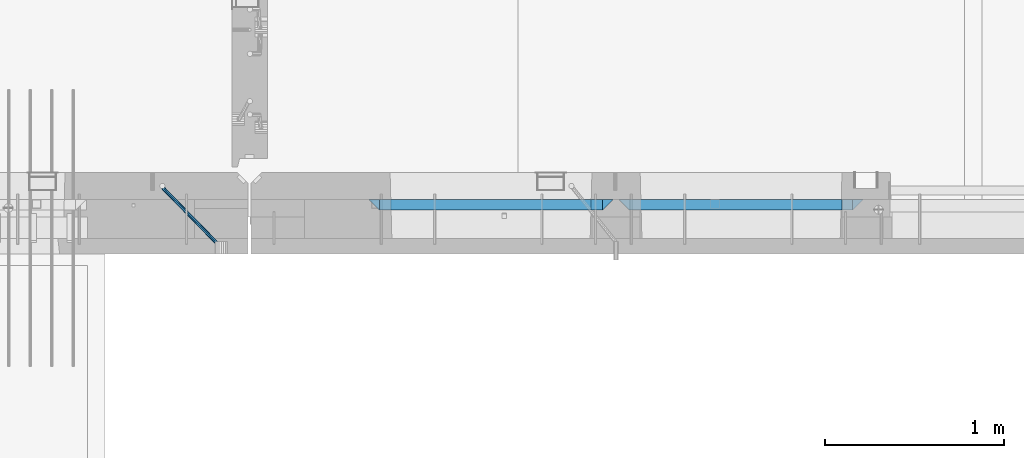
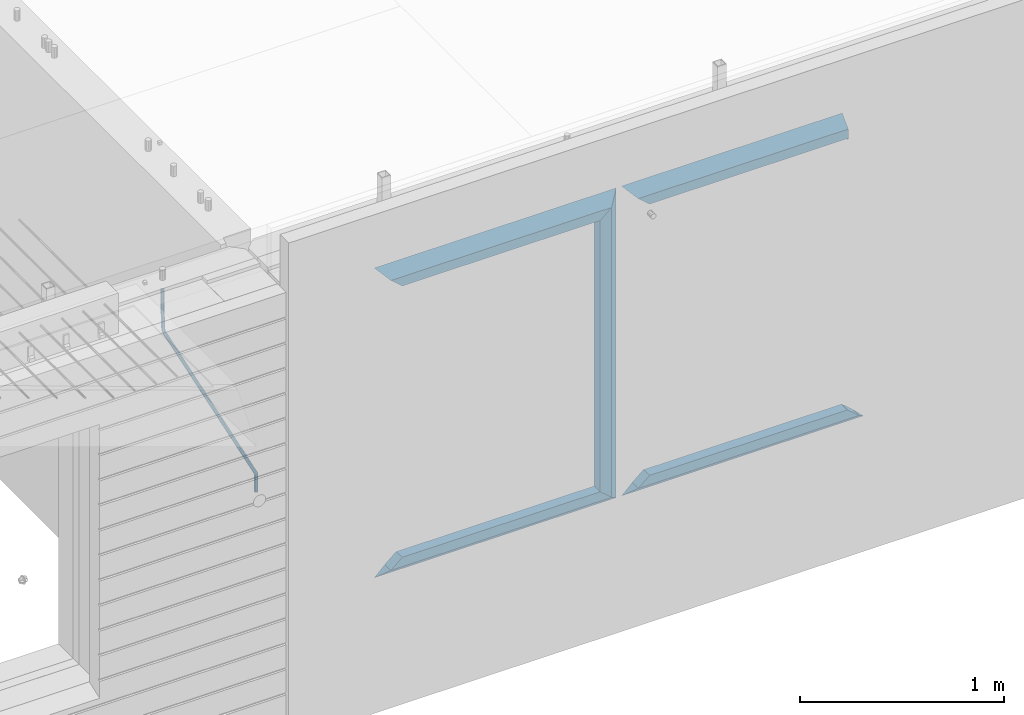
# One storey, part 81 of 309: 11 beams, 2 elements without a shape of their own.
"""IFC2X3 building model written with IfcOpenShell, lengths in millimetres."""

from ifc_helpers import new_model, si_unit, frame, origin_with_axes, place, context, subcontext, project, spatial, faceted_brep, material, type_object, element, aggregate, save


model = new_model("IFC2X3")

# Units and contexts
model_context = context("Model", 3, precision=1e-05, world=origin_with_axes())
body_context = subcontext(model_context, "Body", "Model", "MODEL_VIEW")
ifc_project = project(units=[si_unit("LENGTHUNIT", "METRE", prefix="MILLI"), si_unit("AREAUNIT", "SQUARE_METRE"), si_unit("VOLUMEUNIT", "CUBIC_METRE"), si_unit("MASSUNIT", "GRAM", prefix="KILO"), si_unit("TIMEUNIT", "SECOND"), si_unit("PLANEANGLEUNIT", "RADIAN"), si_unit("SOLIDANGLEUNIT", "STERADIAN"), si_unit("THERMODYNAMICTEMPERATUREUNIT", "DEGREE_CELSIUS"), si_unit("LUMINOUSINTENSITYUNIT", "LUMEN")], contexts=[model_context])

# Site, building, storey
site_placement = place(None, origin_with_axes())
site = spatial("IfcSite", under=ifc_project, at=site_placement, CompositionType="ELEMENT")
building_placement = place(site_placement, origin_with_axes())
building = spatial("IfcBuilding", under=site, at=building_placement, CompositionType="ELEMENT")
storey_placement = place(building_placement, origin_with_axes())
storey = spatial("IfcBuildingStorey", under=building, at=storey_placement, Name="7", CompositionType="ELEMENT", Elevation=0.0)

# Assembly, beam
assembly_1_placement = place(storey_placement, origin_with_axes())
assembly_1 = element("IfcElementAssembly", 1, at=assembly_1_placement, inside=storey, AssemblyPlace="NOTDEFINED", PredefinedType="REINFORCEMENT_UNIT")
ifc_material_1 = material()
beam_type_1 = type_object("IfcBeamType", Name="D20", PredefinedType="NOTDEFINED")
beam_1_placement = place(assembly_1_placement, frame((28120.0219996506, 7924.99999995055, 102407.5), z_axis=(-0.000415599999849952, -0.999999913638316, 0.0), x_axis=(-0.00018169900008877, 0.0, -0.999999983492737)))
beam_1 = element("IfcBeam", 2, at=beam_1_placement, type_object=beam_type_1, material=ifc_material_1, Name="JM20", ObjectType="D20", context=body_context, shape_type="Brep", body=[
    faceted_brep([(-0.00060564729210455, -9.99999998165731, 0.0), (-0.000428079845733009, -7.07106779890455, -7.07106781186667), (119.575515501536, -7.07830994756296, -7.07106481604933), (119.575337932896, -10.0072421307195, -3.43332612828817e-06), (0.0, 0.0, -10.0), (119.575943836026, -0.00724214867295814, -9.99999700418266), (0.00042843479604926, 7.07106779888636, -7.07106781186303), (119.57637202373, 7.06382565022977, -7.07106481604933), (0.00060564729210455, 9.99999998166459, 3.63797880709171e-12), (119.576549238118, 9.99275783300072, 2.99581552098971e-06), (0.000428079845733009, 7.07106779890819, 7.07106781186667), (119.576371669405, 7.06382565024978, 7.07107080768037), (0.0, 0.0, 10.0), (119.57594333493, -0.00724214864203532, 10.0000029958155), (-0.000428434810601175, -7.07106779888272, 7.07106781186667), (119.575515147211, -7.07830994754295, 7.07107080768037), (123.007838984922, -7.07805953274146, -6.96781646693489), (122.583416564885, -10.0070226667376, 0.0904895847234002), (123.182432386879, -0.00697902713727672, -9.89150957511447), (123.004922326727, 7.0640757898218, -6.96792996825661), (122.579291790258, 9.99297690664025, 0.09032907062101), (122.154869373029, 7.06401377197108, 7.14863512328429), (121.980275971029, -0.00706673364766175, 10.0723282314621), (122.157786031181, -7.0781215506031, 7.1487486246051), (232.991069545737, -7.0553235628031, -0.344989315878593), (232.56664713427, -9.98428669916029, 6.71331673826626), (233.165662947809, 0.0157569427356066, -3.26868242414184), (232.988152887861, 7.08681175970924, -0.345102817348561), (232.562522351524, 10.0157128766077, 6.71315622151724), (232.138099934426, 7.08674974201131, 13.7714622742333), (231.963506532353, 0.0156692364653281, 16.6951553824965), (232.141016592301, -7.05538558050466, 13.7715757757042), (248.076986635424, -5.5847993905918, 1.85861828010275), (247.029610002806, -8.57448599522468, 8.8259290931519), (244.875536996158, -5.81406760439131, 15.6317136598209), (242.87659436863, 1.07944012639928, 18.2892356835691), (242.20373560088, 8.06791386077748, 15.2417548051744), (243.251112233527, 11.0576004654249, 8.27444399212709), (245.405185240103, 8.29718207458427, 1.4686594254481), (247.40412786763, 1.40367434377549, -1.1888625983047), (260.566830172145, 5.47100196453175, 3.19131575132906), (262.023113325369, -1.27539050352425, 6.49949830426976), (256.884070167318, 11.8442033958454, 5.28851055269934), (253.132144174728, 14.110878827727, 11.5625744366826), (251.508879555811, 10.9432405336265, 18.3382458712176), (252.965162709021, 4.19684806558143, 21.6464284241465), (256.647922713819, -2.17635336575768, 19.5492336227662), (260.399848700399, -4.44302879667157, 13.2751697364092), (1011.72756124764, 322.959435794994, 337.688425673249), (1010.10429662876, 319.79179750097, 344.464097107826), (1010.27127809466, 329.705828263024, 334.380243120345), (1006.58851809015, 336.079029694381, 336.477437921801), (1002.83659209782, 338.345705126318, 342.751501805859), (1001.21332747894, 335.178066832297, 349.527173240437), (1002.66961063194, 328.431674364263, 352.835355793341), (1006.35237063644, 322.058472932906, 350.738160991886), (1012.15285167976, 323.143366902459, 337.876301685487), (1011.27592458235, 320.298507294498, 344.981674676291), (1011.36533099508, 330.178988123705, 334.863551186057), (1009.37468146477, 337.283999466545, 337.708251560521), (1007.34699858574, 340.296381647149, 344.744015910405), (1006.47007148832, 337.45152203918, 351.849388901209), (1007.25759217299, 330.415900817941, 354.862139400639), (1009.24824170329, 323.310889475106, 352.017439026175), (1012.6528516715, 323.14345775195, 337.876301647731), (1012.65336908352, 320.298757574768, 344.981674572278), (1012.65157305435, 330.179221832586, 334.863551088932), (1012.65028222866, 337.284594639881, 337.708251313175), (1012.64973534261, 340.297345149043, 344.744015509988), (1012.65025275464, 337.452644971851, 351.849388434534), (1012.65153137178, 330.416880891225, 354.862138993334), (1012.65282219746, 323.311508083931, 352.017438769089), (1117.44132683994, 323.162497711652, 337.876293734989), (1117.44184425197, 320.31779753447, 344.981666659536), (1117.44004822278, 330.198261792288, 334.863543176189), (1117.43875739709, 337.303634599582, 337.708243400433), (1117.43821051104, 340.316385108745, 344.744007597245), (1117.43872792307, 337.471684931556, 351.849380521792), (1117.44000654022, 330.435920850927, 354.862131080592), (1117.44129736591, 323.330548043632, 352.017430856347)], [[[0, 1, 2, 3]], [[1, 4, 5, 2]], [[4, 6, 7, 5]], [[6, 8, 9, 7]], [[8, 10, 11, 9]], [[10, 12, 13, 11]], [[12, 14, 15, 13]], [[14, 0, 3, 15]], [[14, 12, 10, 8, 6, 4, 1, 0]], [[3, 2, 16, 17]], [[2, 5, 18, 16]], [[5, 7, 19, 18]], [[7, 9, 20, 19]], [[9, 11, 21, 20]], [[11, 13, 22, 21]], [[13, 15, 23, 22]], [[15, 3, 17, 23]], [[17, 16, 24, 25]], [[16, 18, 26, 24]], [[18, 19, 27, 26]], [[19, 20, 28, 27]], [[20, 21, 29, 28]], [[21, 22, 30, 29]], [[22, 23, 31, 30]], [[23, 17, 25, 31]], [[25, 24, 32, 33]], [[31, 25, 33, 34]], [[30, 31, 34, 35]], [[29, 30, 35, 36]], [[28, 29, 36, 37]], [[27, 28, 37, 38]], [[26, 27, 38, 39]], [[24, 26, 39, 32]], [[39, 40, 41, 32]], [[38, 42, 40, 39]], [[37, 43, 42, 38]], [[36, 44, 43, 37]], [[35, 45, 44, 36]], [[34, 46, 45, 35]], [[33, 47, 46, 34]], [[32, 41, 47, 33]], [[47, 41, 48, 49]], [[41, 40, 50, 48]], [[40, 42, 51, 50]], [[42, 43, 52, 51]], [[43, 44, 53, 52]], [[44, 45, 54, 53]], [[45, 46, 55, 54]], [[46, 47, 49, 55]], [[49, 48, 56, 57]], [[48, 50, 58, 56]], [[50, 51, 59, 58]], [[51, 52, 60, 59]], [[52, 53, 61, 60]], [[53, 54, 62, 61]], [[54, 55, 63, 62]], [[55, 49, 57, 63]], [[57, 56, 64, 65]], [[56, 58, 66, 64]], [[58, 59, 67, 66]], [[59, 60, 68, 67]], [[60, 61, 69, 68]], [[61, 62, 70, 69]], [[62, 63, 71, 70]], [[63, 57, 65, 71]], [[65, 64, 72, 73]], [[64, 66, 74, 72]], [[66, 67, 75, 74]], [[67, 68, 76, 75]], [[68, 69, 77, 76]], [[69, 70, 78, 77]], [[70, 71, 79, 78]], [[71, 65, 73, 79]], [[74, 75, 76, 77, 78, 79, 73, 72]]]),
])
aggregate(assembly_1, [beam_1])

# Assembly, beams
assembly_2_placement = place(storey_placement, origin_with_axes())
assembly_2 = element("IfcElementAssembly", 3, at=assembly_2_placement, inside=storey, AssemblyPlace="NOTDEFINED", PredefinedType="REINFORCEMENT_UNIT")
ifc_material_2 = material(Name="CONCRETE/C35/45")
beam_type_2 = type_object("IfcBeamType", PredefinedType="NOTDEFINED")
beam_2_placement = place(assembly_2_placement, frame((30674.9996552717, 7820.0, 102145.0), z_axis=(0.0, 0.0, -1.0), x_axis=(1.0, 0.0, 0.0)))
beam_2 = element("IfcBeam", 4, at=beam_2_placement, type_object=beam_type_2, material=ifc_material_2, Name="SK", context=body_context, shape_type="Brep", body=[
    faceted_brep([(1249.99847412109, -30.0, 30.0), (1249.99847412109, -29.999999998452, -30.0), (1249.99847412109, 30.0, 30.0), (60.0000000000073, -30.0, 30.0), (0.0, -30.0, -30.0), (60.0000000000073, 30.0, 30.0)], [[[0, 1, 2]], [[1, 0, 3, 4]], [[2, 1, 4, 5]], [[0, 2, 5, 3]], [[5, 4, 3]]]),
])
beam_3_placement = place(assembly_2_placement, frame((30734.9996552717, 7820.0, 102085.0), z_axis=(0.0, 0.0, -1.0), x_axis=(1.0, 0.0, 0.0)))
beam_3 = element("IfcBeam", 5, at=beam_3_placement, type_object=beam_type_2, material=ifc_material_2, Name="SK", context=body_context, shape_type="Brep", body=[
    faceted_brep([(1189.99847412109, -30.0, 30.0), (1189.99847412109, -30.0, -30.0), (1189.99847412109, 30.0, -30.0), (1189.99847412109, 30.0, 30.0), (1184.32279844542, 30.0, 30.0), (1185.94442006704, -30.0, 30.0), (1184.32279844542, 29.999999998452, 25.6756756756804), (1185.94442006696, -29.999999998452, 24.0540540541406), (65.6741497967687, 29.999999998452, 25.6756756756804), (64.0525281752307, -29.999999998452, 24.0540540541406), (65.6741497967687, 29.999999998452, 26.2921283848846), (64.0525281752307, -29.999999998452, 24.9021669953072), (0.0, -30.0, -30.0), (0.0, 30.0, -30.0)], [[[0, 1, 2, 3]], [[0, 3, 4, 5]], [[5, 4, 6, 7]], [[7, 6, 8, 9]], [[9, 8, 10, 11]], [[1, 0, 5, 7, 9, 11, 12]], [[2, 1, 12, 13]], [[8, 6, 4, 3, 2, 13, 10]], [[10, 13, 12, 11]]]),
])
ifc_material_3 = material(Name="CONCRETE/C30/37")
beam_4_placement = place(assembly_2_placement, frame((32044.9981293928, 7820.0, 100350.0), z_axis=(0.0, 0.0, 1.0), x_axis=(-1.0, 3.00000001838171e-08, 0.0)))
beam_4 = element("IfcBeam", 6, at=beam_4_placement, type_object=beam_type_2, material=ifc_material_3, Name="SK", context=body_context, shape_type="Brep", body=[
    faceted_brep([(1309.99847412109, 30.0, 30.0), (1309.99847412109, -30.0, 30.0), (1369.99847412109, -30.0, -30.0), (0.0, -30.0, -30.0), (60.0000000000073, 30.0, 30.0), (60.0000000000073, -30.0, 30.0)], [[[0, 1, 2]], [[3, 4, 0, 2]], [[4, 5, 1, 0]], [[5, 3, 2, 1]], [[4, 3, 5]]]),
])
beam_5_placement = place(assembly_2_placement, frame((31984.9981293928, 7820.0, 100410.0), z_axis=(0.0, 0.0, 1.0), x_axis=(-1.0, 3.00000001838171e-08, 0.0)))
beam_5 = element("IfcBeam", 7, at=beam_5_placement, type_object=beam_type_2, material=ifc_material_3, Name="SK", context=body_context, shape_type="Brep", body=[
    faceted_brep([(1185.94594588314, -29.9999988381387, 24.0540541168593), (1184.32432432432, 29.9999988381387, 25.6756756756804), (65.6756756756768, 30.0, 25.6756756756804), (64.0540540540533, -30.0, 24.0540540540533), (1185.94594594586, -29.999999998452, 24.9021669952926), (1184.32432432433, 29.999999998452, 26.2921283848846), (1249.99847412109, -29.999999998452, -30.0), (1249.99847412109, 29.999999998452, -30.0), (0.0, -30.0, -30.0), (0.0, 30.0, -30.0), (65.6756756756768, 30.0, 26.293436281092), (64.0540540540533, -30.0, 24.9034748914419)], [[[0, 1, 2, 3]], [[1, 0, 4, 5]], [[5, 4, 6, 7]], [[8, 9, 7, 6]], [[2, 1, 5, 7, 9, 10]], [[3, 2, 10, 11]], [[6, 4, 0, 3, 11, 8]], [[8, 11, 10, 9]]]),
])
beam_6_placement = place(assembly_2_placement, frame((29275.0000367414, 7820.0, 102145.0), z_axis=(0.0, 0.0, -1.0), x_axis=(1.0, 0.0, 0.0)))
beam_6 = element("IfcBeam", 8, at=beam_6_placement, type_object=beam_type_2, material=ifc_material_2, Name="SK", context=body_context, shape_type="Brep", body=[
    faceted_brep([(60.0000000000073, 30.0, 30.0), (0.0, -30.0, -30.0), (60.0000000000073, -30.0, 30.0), (1370.00038146973, -30.0, -30.0), (1310.0003814697, -30.0, 30.0), (1310.0003814697, 30.0, 30.0)], [[[0, 1, 2]], [[2, 1, 3, 4]], [[0, 2, 4, 5]], [[1, 0, 5, 3]], [[3, 5, 4]]]),
])
beam_7_placement = place(assembly_2_placement, frame((29335.0000367414, 7820.0, 102085.0), z_axis=(0.0, 0.0, -1.0), x_axis=(1.0, 0.0, 0.0)))
beam_7 = element("IfcBeam", 9, at=beam_7_placement, type_object=beam_type_2, material=ifc_material_2, Name="SK", context=body_context, shape_type="Brep", body=[
    faceted_brep([(1185.94632735287, -29.9999988381387, 24.0540541168593), (1184.32470579405, 29.9999988381387, 25.6756756756804), (65.6760571454033, 29.9999988381387, 25.6756756756804), (64.0544355865859, -29.9999988381387, 24.0540541168593), (65.6760571454033, 29.9999988381387, 26.2937632551475), (64.0544355865859, -29.9999988381387, 24.9038019193104), (0.0, 30.0, -30.0), (0.0, -30.0, -30.0), (1250.00038146973, -29.9999988381387, -30.0), (1185.94632735287, -29.9999988381387, 24.9034749452549), (1184.32470579405, 29.9999988381387, 26.2934362810629), (1250.00038146973, 29.9999988381387, -30.0)], [[[0, 1, 2, 3]], [[3, 2, 4, 5]], [[5, 4, 6, 7]], [[0, 3, 5, 7, 8, 9]], [[1, 0, 9, 10]], [[6, 4, 2, 1, 10, 11]], [[7, 6, 11, 8]], [[8, 11, 10, 9]]]),
])
beam_8_placement = place(assembly_2_placement, frame((30615.0004182112, 7820.0, 102175.0), z_axis=(-1.0, 3.00000001838171e-08, 0.0), x_axis=(0.0, 0.0, -1.0)))
beam_8 = element("IfcBeam", 10, at=beam_8_placement, type_object=beam_type_2, material=ifc_material_2, Name="SK", context=body_context, shape_type="Brep", body=[
    faceted_brep([(60.0000000000073, 30.0, 30.0), (0.0, -30.0, -30.0), (60.0000000000073, -30.0, 30.0), (1855.0, -30.0, -30.0), (1795.00000000001, -30.0, 30.0), (1795.00000000001, 30.0, 30.0)], [[[0, 1, 2]], [[3, 4, 2, 1]], [[4, 5, 0, 2]], [[5, 3, 1, 0]], [[4, 3, 5]]]),
])
beam_9_placement = place(assembly_2_placement, frame((30645.0004182112, 7820.0, 100350.0), z_axis=(0.0, 0.0, 1.0), x_axis=(-1.0, 3.00000001838171e-08, 0.0)))
beam_9 = element("IfcBeam", 11, at=beam_9_placement, type_object=beam_type_2, material=ifc_material_3, Name="SK", context=body_context, shape_type="Brep", body=[
    faceted_brep([(1370.00038146973, -30.0, -30.0), (1310.0003814697, 30.0, 30.0), (1310.0003814697, -30.0, 30.0), (0.0, -30.0, -30.0), (60.0000000000073, 30.0, 30.0), (60.0000000000073, -30.0, 30.0)], [[[0, 1, 2]], [[3, 4, 1, 0]], [[4, 5, 2, 1]], [[5, 3, 0, 2]], [[4, 3, 5]]]),
])
beam_10_placement = place(assembly_2_placement, frame((30585.0004182112, 7820.0, 100410.0), z_axis=(0.0, 0.0, 1.0), x_axis=(-1.0, 3.00000001838171e-08, 0.0)))
beam_10 = element("IfcBeam", 12, at=beam_10_placement, type_object=beam_type_2, material=ifc_material_3, Name="SK", context=body_context, shape_type="Brep", body=[
    faceted_brep([(1185.94594588314, -29.9999988381387, 24.0540541168593), (1184.32432432432, 29.9999988381387, 25.6756756756804), (65.6756756756768, 30.0, 25.6756756756804), (64.0540540540533, -30.0, 24.0540540540533), (1185.94594588314, -29.9999988381387, 24.9038019193104), (1184.32432432432, 29.9999988381387, 26.2937632551329), (1250.00038146973, -29.9999988381387, -30.0), (1250.00038146973, 29.9999988381387, -30.0), (0.0, -30.0, -30.0), (0.0, 30.0, -30.0), (65.6756756756768, 30.0, 26.293436281092), (64.0540540540533, -30.0, 24.9034748914419)], [[[0, 1, 2, 3]], [[1, 0, 4, 5]], [[4, 6, 7, 5]], [[8, 9, 7, 6]], [[2, 1, 5, 7, 9, 10]], [[3, 2, 10, 11]], [[6, 4, 0, 3, 11, 8]], [[8, 11, 10, 9]]]),
])
beam_type_3 = type_object("IfcBeamType", PredefinedType="NOTDEFINED")
beam_11_placement = place(assembly_2_placement, frame((30550.0004182112, 7820.0, 102115.0), z_axis=(-1.0, 3.00000001838171e-08, 0.0), x_axis=(0.0, 0.0, -1.0)))
beam_11 = element("IfcBeam", 13, at=beam_11_placement, type_object=beam_type_3, material=ifc_material_2, Name="SK", context=body_context, shape_type="Brep", body=[
    faceted_brep([(0.0, -30.0, -35.0), (54.9034748914273, -30.0, 29.0540540540533), (56.2934362811066, 30.0, 30.6756756756768), (0.0, 30.0, -35.0), (1735.0, -30.0, -35.0), (1680.09652510857, -30.0, 29.0540540540533), (1678.70656371891, 30.0, 30.6756756756768), (1735.0, 30.0, -35.0)], [[[0, 1, 2, 3]], [[1, 0, 4, 5]], [[2, 1, 5, 6]], [[3, 2, 6, 7]], [[7, 4, 0, 3]], [[4, 7, 6, 5]]]),
])
aggregate(assembly_2, [beam_2, beam_3, beam_4, beam_5, beam_6, beam_7, beam_8, beam_11, beam_9, beam_10])

save(model, "model.ifc")
